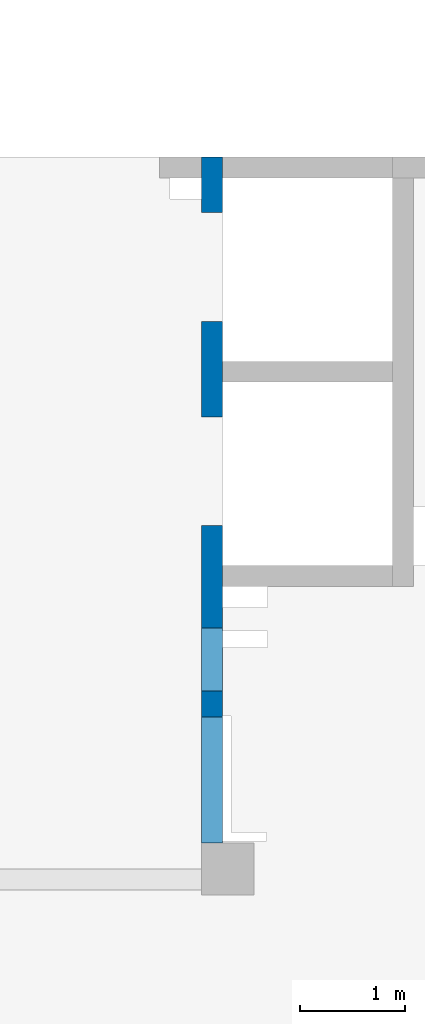
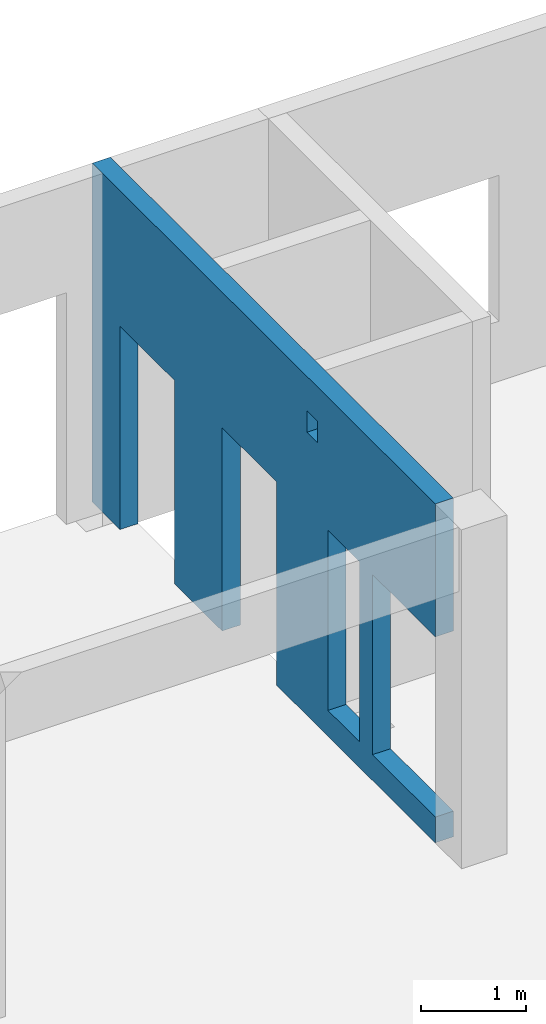
# One storey, part 6 of 8: 1 wall, 5 openings.
"""IFC4 building model written with IfcOpenShell, lengths in millimetres."""

from ifc_helpers import new_model, entity, si_unit, converted_unit, derived_unit, direction, frame, origin, place, context, subcontext, project, spatial, indexed_curve, outline, extrude, polygons, material, type_object, element, save


model = new_model("IFC4")

# Units and contexts
model_context = context("Model", 3, precision=0.01, world=origin(), true_north=direction((6.12303176911189e-17, 1.0)))
plan_context = context("Plan", 3, precision=0.01, world=origin(), true_north=direction((6.12303176911189e-17, 1.0)))
body_context = subcontext(model_context, "Body", "Model", "MODEL_VIEW")
ifc_project = project(units=[si_unit("LENGTHUNIT", "METRE", prefix="MILLI"), si_unit("AREAUNIT", "SQUARE_METRE"), si_unit("VOLUMEUNIT", "CUBIC_METRE"), converted_unit("PLANEANGLEUNIT", "DEGREE", entity("IfcRatioMeasure", 0.0174532925199433), si_unit("PLANEANGLEUNIT", "RADIAN"), dimensions=[0, 0, 0, 0, 0, 0, 0]), si_unit("MASSUNIT", "GRAM", prefix="KILO"), derived_unit("MASSDENSITYUNIT", [(si_unit("MASSUNIT", "GRAM", prefix="KILO"), 1), (si_unit("LENGTHUNIT", "METRE"), -3)]), derived_unit("MOMENTOFINERTIAUNIT", [(si_unit("LENGTHUNIT", "METRE"), 4)]), si_unit("TIMEUNIT", "SECOND"), si_unit("FREQUENCYUNIT", "HERTZ"), si_unit("THERMODYNAMICTEMPERATUREUNIT", "DEGREE_CELSIUS"), derived_unit("THERMALTRANSMITTANCEUNIT", [(si_unit("MASSUNIT", "GRAM", prefix="KILO"), 1), (si_unit("THERMODYNAMICTEMPERATUREUNIT", "KELVIN"), -1), (si_unit("TIMEUNIT", "SECOND"), -3)]), derived_unit("VOLUMETRICFLOWRATEUNIT", [(si_unit("LENGTHUNIT", "METRE"), 3), (si_unit("TIMEUNIT", "SECOND"), -1)]), derived_unit("MASSFLOWRATEUNIT", [(si_unit("MASSUNIT", "GRAM", prefix="KILO"), 1), (si_unit("TIMEUNIT", "SECOND"), -1)]), derived_unit("ROTATIONALFREQUENCYUNIT", [(si_unit("TIMEUNIT", "SECOND"), -1)]), si_unit("ELECTRICCURRENTUNIT", "AMPERE"), si_unit("ELECTRICVOLTAGEUNIT", "VOLT"), si_unit("POWERUNIT", "WATT"), si_unit("FORCEUNIT", "NEWTON", prefix="KILO"), si_unit("ILLUMINANCEUNIT", "LUX"), si_unit("LUMINOUSFLUXUNIT", "LUMEN"), si_unit("LUMINOUSINTENSITYUNIT", "CANDELA"), derived_unit("USERDEFINED", [(si_unit("MASSUNIT", "GRAM", prefix="KILO"), -1), (si_unit("LENGTHUNIT", "METRE"), -2), (si_unit("TIMEUNIT", "SECOND"), 3), (si_unit("LUMINOUSFLUXUNIT", "LUMEN"), 1)]), derived_unit("LINEARVELOCITYUNIT", [(si_unit("LENGTHUNIT", "METRE"), 1), (si_unit("TIMEUNIT", "SECOND"), -1)]), si_unit("PRESSUREUNIT", "PASCAL"), derived_unit("USERDEFINED", [(si_unit("LENGTHUNIT", "METRE"), -2), (si_unit("MASSUNIT", "GRAM", prefix="KILO"), 1), (si_unit("TIMEUNIT", "SECOND"), -2)]), derived_unit("LINEARFORCEUNIT", [(si_unit("MASSUNIT", "GRAM", prefix="KILO"), 1), (si_unit("LENGTHUNIT", "METRE"), 1), (si_unit("TIMEUNIT", "SECOND"), -2), (si_unit("LENGTHUNIT", "METRE"), -1)]), derived_unit("PLANARFORCEUNIT", [(si_unit("MASSUNIT", "GRAM", prefix="KILO"), 1), (si_unit("LENGTHUNIT", "METRE"), 1), (si_unit("TIMEUNIT", "SECOND"), -2), (si_unit("LENGTHUNIT", "METRE"), -2)])], contexts=[model_context, plan_context])

# Site, building, storey
site_placement = place(None, origin())
site = spatial("IfcSite", under=ifc_project, at=site_placement, CompositionType="ELEMENT")
building_placement = place(site_placement, origin())
building = spatial("IfcBuilding", under=site, at=building_placement, CompositionType="ELEMENT")
storey_placement = place(building_placement, frame((0.0, 0.0, 24000.0)))
storey = spatial("IfcBuildingStorey", under=building, at=storey_placement, CompositionType="ELEMENT", Elevation=24000.0)

# Wall, openings
ifc_material = material()
wall_type = type_object("IfcWallType", PredefinedType="STANDARD")
wall_placement = place(storey_placement, frame((16000.0002685547, 20499.9998657227, -150.0), z_axis=(0.0, 0.0, 1.0), x_axis=(0.0, -1.0, 0.0)))
wall = element("IfcWall", 1, at=wall_placement, inside=storey, type_object=wall_type, material=ifc_material, PredefinedType="NOTDEFINED", context=body_context, shape_type="Tessellation", body=[
    polygons([(6550.00048980714, -99.9999999999982, 3950.0), (200.000000000002, -100.0, 3950.0), (0.0, -100.0, 3950.0), (0.0, -100.0, 0.0), (200.000000000002, -100.0, 0.0), (529.999999999996, -99.9999999999995, 0.0), (529.999999999996, -99.9999999999995, 2369.99999999805), (1570.0, -100.000000000002, 2369.99999999805), (1570.0, -100.000000000002, 0.0), (2480.0, -100.000000000001, 0.0), (2480.0, -100.000000000001, 2369.99999999805), (3519.99999999999, -100.000000000001, 2369.99999999805), (3519.99999999999, -100.000000000001, 0.0), (6550.00048980714, -99.9999999999982, 0.0), (6550.00048980714, -99.9999999999982, 300.000000000001), (5350.00048980714, -100.0, 300.000000000001), (5350.00048980714, -100.0, 2399.99999999998), (6550.00048980714, -99.9999999999982, 2399.99999999999), (4100.00063936683, -100.000000000321, 3549.99999999999), (4300.00063936683, -100.00000000032, 3549.99999999999), (4300.00063936683, -100.00000000032, 3300.00000000001), (4100.00063936683, -100.000000000321, 3300.00000000001), (4500.00063936683, -99.9999999999995, 2399.99999999999), (5100.00063936683, -100.000000000001, 2399.99999999999), (5100.00063936683, -100.000000000001, 300.000000000001), (4500.00063936683, -99.9999999999995, 300.000000000001), (4300.00063936683, 100.0, 3549.99999999999), (4100.00063936683, 99.9999999999999, 3549.99999999999), (4100.00063936683, 99.9999999999999, 3300.00000000001), (4300.00063936683, 100.0, 3300.00000000001), (5100.00063936683, 99.9999999999994, 2399.99999999999), (4500.00063936683, 99.9999999999984, 2399.99999999998), (4500.00063936683, 99.9999999999984, 300.000000000001), (5100.00063936683, 99.9999999999994, 300.000000000001), (0.0, 99.9999999999996, 3950.0), (200.000000000002, 99.9999999999999, 3950.0), (1950.0, 100.000000000001, 3950.0), (2150.0, 99.9999999999988, 3950.0), (3900.00063936683, 99.9999999999995, 3950.0), (4100.00063936683, 99.9999999999999, 3950.0), (6550.00048980714, 99.9999999999996, 3950.0), (6550.00048980714, 99.9999999999996, 2399.99999999999), (5350.00048980714, 99.9999999999998, 2399.99999999998), (5350.00048980714, 99.9999999999998, 300.000000000001), (6550.00048980714, 99.9999999999996, 300.000000000001), (6550.00048980714, 99.9999999999996, 0.0), (4100.00063936683, 99.9999999999999, 0.0), (3900.00063936683, 99.9999999999995, 0.0), (3519.99999999999, 99.9999999999989, 0.0), (3519.99999999999, 99.9999999999989, 2369.99999999805), (2480.0, 100.000000000002, 2369.99999999804), (2480.0, 100.000000000002, 0.0), (1570.0, 100.0, 0.0), (1570.0, 100.0, 2369.99999999805), (529.999999999996, 100.0, 2369.99999999804), (529.999999999996, 100.0, 0.0), (0.0, 99.9999999999996, 0.0)], [[[1, 2, 3, 4, 5, 6, 7, 8, 9, 10, 11, 12, 13, 14, 15, 16, 17, 18], [19, 20, 21, 22], [23, 24, 25, 26]], [[35, 36, 37, 38, 39, 40, 41, 42, 43, 44, 45, 46, 47, 48, 49, 50, 51, 52, 53, 54, 55, 56, 57], [27, 28, 29, 30], [31, 32, 33, 34]], [[4, 57, 56, 6, 5]], [[14, 46, 45, 15]], [[3, 2, 1, 41, 40, 39, 38, 37, 36, 35]], [[4, 3, 35, 57]], [[20, 19, 28, 27]], [[20, 27, 30, 21]], [[21, 30, 29, 22]], [[28, 19, 22, 29]], [[31, 24, 23, 32]], [[32, 23, 26, 33]], [[33, 26, 25, 34]], [[24, 31, 34, 25]], [[17, 43, 42, 18]], [[43, 17, 16, 44]], [[44, 16, 15, 45]], [[50, 12, 11, 51]], [[51, 11, 10, 52]], [[12, 50, 49, 13]], [[54, 8, 7, 55]], [[55, 7, 6, 56]], [[8, 54, 53, 9]], [[41, 1, 18, 42]], [[52, 10, 9, 53]], [[46, 14, 13, 49, 48, 47]]], closed=True),
])
opening_1_placement = place(wall_placement, frame((20499.9998657227, -16000.0002685547, 150.0), z_axis=(0.0, 0.0, 1.0), x_axis=(0.0, 1.0, 0.0)))
element("IfcOpeningElement", 2, at=opening_1_placement, cuts=wall, PredefinedType="OPENING", context=body_context, shape_type="SweptSolid", body=[
    extrude(outline(indexed_curve([(-1049.99999999999, -600.0), (1050.0, -600.0), (1050.0, 600.0), (-1049.99999999999, 600.0), (-1049.99999999999, -600.0)], self_intersect=False)), frame((15800.0002685547, 14549.9993759155, 1200.0), z_axis=(1.0, 0.0, 0.0), x_axis=(0.0, 0.0, -1.0)), (0.0, 0.0, 1.0), 400.000000001943),
])
opening_2_placement = place(wall_placement, frame((20499.9998657227, -16000.0002685547, 150.0), z_axis=(0.0, 0.0, 1.0), x_axis=(0.0, 1.0, 0.0)))
element("IfcOpeningElement", 3, at=opening_2_placement, cuts=wall, PredefinedType="OPENING", context=body_context, shape_type="SweptSolid", body=[
    extrude(outline(indexed_curve([(-1184.99999999902, -520.000000000001), (1184.99999999902, -520.000000000001), (1184.99999999902, 519.999999999999), (-1184.99999999902, 519.999999999999), (-1184.99999999902, -520.000000000001)], self_intersect=False)), frame((15800.0002685547, 17499.9998657227, 1035.0), z_axis=(1.0, 0.0, 0.0), x_axis=(0.0, 0.0, -1.0)), (0.0, 0.0, 1.0), 400.000000001943),
])
opening_3_placement = place(wall_placement, frame((20499.9998657227, -16000.0002685547, 150.0), z_axis=(0.0, 0.0, 1.0), x_axis=(0.0, 1.0, 0.0)))
element("IfcOpeningElement", 4, at=opening_3_placement, cuts=wall, PredefinedType="OPENING", context=body_context, shape_type="SweptSolid", body=[
    extrude(outline(indexed_curve([(-1184.99999999902, -519.999999999999), (1184.99999999902, -519.999999999999), (1184.99999999902, 520.000000000001), (-1184.99999999902, 520.000000000001), (-1184.99999999902, -519.999999999999)], self_intersect=False)), frame((15800.0002685547, 19449.9998657227, 1035.0), z_axis=(1.0, 0.0, 0.0), x_axis=(0.0, 0.0, -1.0)), (0.0, 0.0, 1.0), 400.000000001943),
])
opening_4_placement = place(wall_placement, frame((20499.9998657227, -16000.0002685547, 150.0), z_axis=(0.0, 0.0, 1.0), x_axis=(0.0, 1.0, 0.0)))
element("IfcOpeningElement", 5, at=opening_4_placement, cuts=wall, PredefinedType="OPENING", context=body_context, shape_type="SweptSolid", body=[
    extrude(outline(indexed_curve([(-100.000000000001, -124.999999999993), (99.9999999999989, -124.999999999993), (99.9999999999989, 124.999999999993), (-100.000000000001, 124.999999999993), (-100.000000000001, -124.999999999993)], self_intersect=False)), frame((15900.0002685537, 16299.9992263558, 3275.0), z_axis=(1.0, 0.0, 0.0), x_axis=(0.0, -1.0, 0.0)), (0.0, 0.0, 1.0), 200.000000000962),
])
opening_5_placement = place(wall_placement, frame((20499.9998657227, -16000.0002685547, 150.0), z_axis=(0.0, 0.0, 1.0), x_axis=(0.0, 1.0, 0.0)))
element("IfcOpeningElement", 6, at=opening_5_placement, cuts=wall, PredefinedType="OPENING", context=body_context, shape_type="SweptSolid", body=[
    extrude(outline(indexed_curve([(-1049.99999999999, -300.000000000001), (1050.0, -300.000000000001), (1050.0, 299.999999999999), (-1049.99999999999, 299.999999999999), (-1049.99999999999, -300.000000000001)], self_intersect=False)), frame((15800.0002685547, 15699.9992263558, 1200.0), z_axis=(1.0, 0.0, 0.0), x_axis=(0.0, 0.0, -1.0)), (0.0, 0.0, 1.0), 400.000000001943),
])

save(model, "model.ifc")
